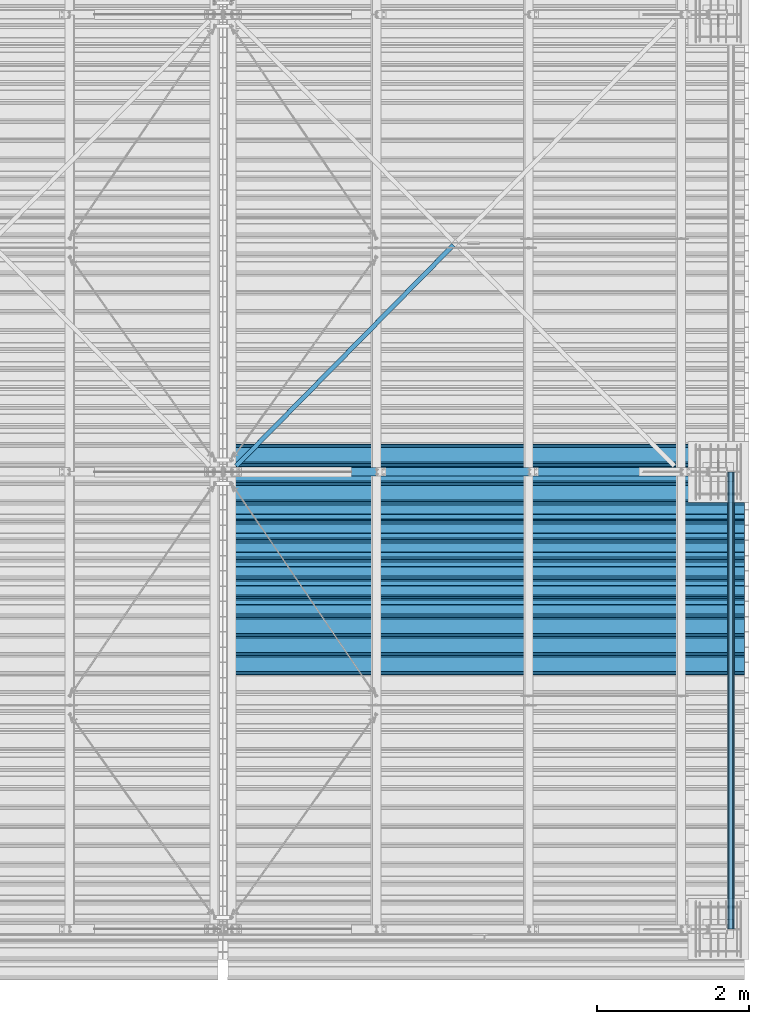
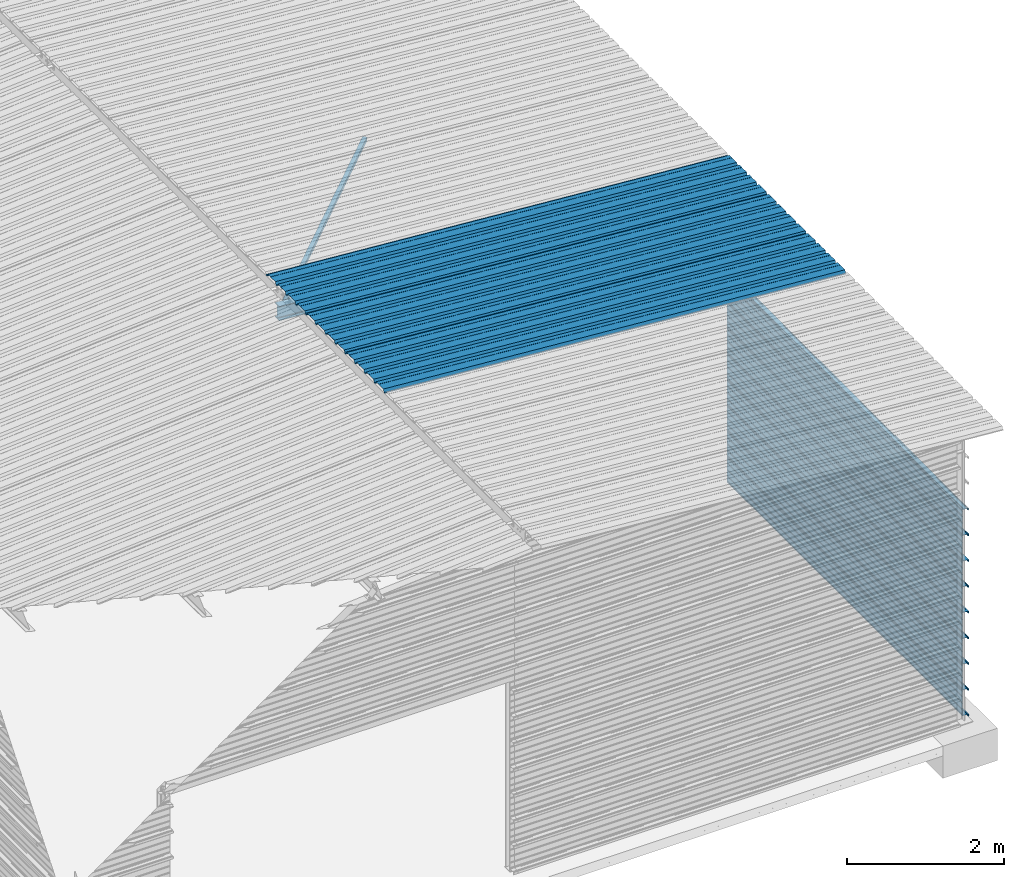
# One storey, part 9 of 70: 13 beams, 13 elements without a shape of their own.
"""IFC2X3 building model written with IfcOpenShell, lengths in millimetres."""

from ifc_helpers import new_model, si_unit, frame, origin_with_axes, origin_2d_with_axis, place, context, subcontext, project, spatial, polyline, i_section, l_section, outline, extrude, clip, halfspace, material, type_object, element, aggregate, save


model = new_model("IFC2X3")

# Units and contexts
model_context = context("Model", 3, precision=1e-05, world=origin_with_axes())
body_context = subcontext(model_context, "Body", "Model", "MODEL_VIEW")
ifc_project = project(units=[si_unit("LENGTHUNIT", "METRE", prefix="MILLI"), si_unit("AREAUNIT", "SQUARE_METRE"), si_unit("VOLUMEUNIT", "CUBIC_METRE"), si_unit("MASSUNIT", "GRAM", prefix="KILO"), si_unit("TIMEUNIT", "SECOND"), si_unit("PLANEANGLEUNIT", "RADIAN"), si_unit("SOLIDANGLEUNIT", "STERADIAN"), si_unit("THERMODYNAMICTEMPERATUREUNIT", "DEGREE_CELSIUS"), si_unit("LUMINOUSINTENSITYUNIT", "LUMEN")], contexts=[model_context])

# Site, building, storey
site_placement = place(None, origin_with_axes())
site = spatial("IfcSite", under=ifc_project, at=site_placement, CompositionType="ELEMENT")
building_placement = place(site_placement, origin_with_axes())
building = spatial("IfcBuilding", under=site, at=building_placement, Name="Undefined", CompositionType="ELEMENT")
storey_placement = place(building_placement, origin_with_axes())
storey = spatial("IfcBuildingStorey", under=building, at=storey_placement, Name="Undefined", CompositionType="ELEMENT", Elevation=0.0)

# Assembly, beam
assembly_1_placement = place(storey_placement, origin_with_axes())
assembly_1 = element("IfcElementAssembly", 1, at=assembly_1_placement, inside=storey, Name="Steel Assembly", AssemblyPlace="NOTDEFINED", PredefinedType="RIGID_FRAME")
ifc_material = material(Name="STEEL/S235JR")
beam_type_1 = type_object("IfcBeamType", Name="4.40", PredefinedType="NOTDEFINED")
beam_1_placement = place(assembly_1_placement, frame((6563.60751131961, 3850.00000000015, 5336.31760454361), z_axis=(-0.0766964990376782, 0.0, -0.997054485489817), x_axis=(0.997054485489817, 0.0, -0.0766964990376783)))
beam_1 = element("IfcBeam", 2, at=beam_1_placement, type_object=beam_type_1, material=ifc_material, ObjectType="4.40", context=body_context, shape_type="SweptSolid", body=[
    extrude(outline(polyline([(509.415161132813, 19.5000000011705), (490.584838867188, 19.5000000011705), (468.084838867188, -20.4999999988113), (406.585784912109, -20.4999999988113), (404.585784912109, -18.4999999988122), (345.414215087891, -18.4999999988122), (343.414215087891, -20.4999999988113), (281.915161132813, -20.4999999988113), (259.415161132813, 19.5000000011705), (240.584854125977, 19.5000000011705), (218.084854125977, -20.4999999988113), (156.585784912109, -20.4999999988113), (154.585784912109, -18.4999999988122), (95.4142150878906, -18.4999999988122), (93.4142150878906, -20.4999999988113), (31.9151515960693, -20.4999999988113), (9.41515254974365, 19.5000000011705), (-9.41515254974365, 19.5000000011705), (-31.9151515960693, -20.4999999988113), (-93.4142150878906, -20.4999999988113), (-95.4142150878906, -18.4999999988122), (-154.585784912109, -18.4999999988122), (-156.585784912109, -20.4999999988113), (-218.084854125977, -20.4999999988113), (-240.584854125977, 19.5000000011705), (-259.415161132813, 19.5000000011705), (-281.915161132813, -20.4999999988113), (-343.414215087891, -20.4999999988113), (-345.414215087891, -18.4999999988122), (-404.585784912109, -18.4999999988122), (-406.585784912109, -20.4999999988113), (-468.084838867188, -20.4999999988113), (-490.584838867188, 19.5000000011705), (-509.415161132813, 19.5000000011705), (-516.482360839844, 6.9361057293263), (-517.353942871094, 7.42636680720625), (-510.0, 20.5000000011705), (-490.0, 20.5000000011705), (-467.5, -19.4999999988122), (-407.0, -19.4999999988122), (-405.0, -17.4999999988131), (-345.0, -17.4999999988131), (-343.0, -19.4999999988122), (-282.5, -19.4999999988122), (-260.0, 20.5000000011705), (-240.0, 20.5000000011705), (-217.5, -19.4999999988122), (-157.0, -19.4999999988122), (-155.0, -17.4999999988131), (-95.0, -17.4999999988131), (-93.0, -19.4999999988122), (-32.5, -19.4999999988122), (-10.0, 20.5000000011705), (10.0, 20.5000000011705), (32.5, -19.4999999988122), (93.0, -19.4999999988122), (95.0, -17.4999999988131), (155.0, -17.4999999988131), (157.0, -19.4999999988122), (217.5, -19.4999999988122), (240.0, 20.5000000011705), (260.0, 20.5000000011705), (282.5, -19.4999999988122), (343.0, -19.4999999988122), (345.0, -17.4999999988131), (405.0, -17.4999999988131), (407.0, -19.4999999988122), (467.5, -19.4999999988122), (490.0, 20.5000000011705), (510.0, 20.5000000011705), (517.353942871094, 7.42636680720625), (516.482360839844, 6.9361057293263), (509.415161132813, 19.5000000011705)])), frame((6799.99999999733, 2.8421709430404e-14, 0.0), z_axis=(-1.0, 0.0, 0.0), x_axis=(0.0, -1.0, 0.0)), (0.0, 0.0, 1.0), 6800.0),
])
aggregate(assembly_1, [beam_1])

assembly_2_placement = place(storey_placement, origin_with_axes())
assembly_2 = element("IfcElementAssembly", 3, at=assembly_2_placement, inside=storey, Name="Steel Assembly", AssemblyPlace="NOTDEFINED", PredefinedType="RIGID_FRAME")
beam_2_placement = place(assembly_2_placement, frame((6563.60751131961, 4850.00000000015, 5336.31760454364), z_axis=(-0.0766964990376782, 0.0, -0.997054485489817), x_axis=(0.997054485489817, 0.0, -0.0766964990376783)))
beam_2 = element("IfcBeam", 4, at=beam_2_placement, type_object=beam_type_1, material=ifc_material, ObjectType="4.40", context=body_context, shape_type="SweptSolid", body=[
    extrude(outline(polyline([(509.415161132813, 19.5000000011705), (490.584838867188, 19.5000000011705), (468.084838867188, -20.4999999988113), (406.585784912109, -20.4999999988113), (404.585784912109, -18.4999999988122), (345.414215087891, -18.4999999988122), (343.414215087891, -20.4999999988113), (281.915161132813, -20.4999999988113), (259.415161132813, 19.5000000011705), (240.584854125977, 19.5000000011705), (218.084854125977, -20.4999999988113), (156.585784912109, -20.4999999988113), (154.585784912109, -18.4999999988122), (95.4142150878906, -18.4999999988122), (93.4142150878906, -20.4999999988113), (31.9151515960693, -20.4999999988113), (9.41515254974365, 19.5000000011705), (-9.41515254974365, 19.5000000011705), (-31.9151515960693, -20.4999999988113), (-93.4142150878906, -20.4999999988113), (-95.4142150878906, -18.4999999988122), (-154.585784912109, -18.4999999988122), (-156.585784912109, -20.4999999988113), (-218.084854125977, -20.4999999988113), (-240.584854125977, 19.5000000011705), (-259.415161132813, 19.5000000011705), (-281.915161132813, -20.4999999988113), (-343.414215087891, -20.4999999988113), (-345.414215087891, -18.4999999988122), (-404.585784912109, -18.4999999988122), (-406.585784912109, -20.4999999988113), (-468.084838867188, -20.4999999988113), (-490.584838867188, 19.5000000011705), (-509.415161132813, 19.5000000011705), (-516.482360839844, 6.9361057293263), (-517.353942871094, 7.42636680720625), (-510.0, 20.5000000011705), (-490.0, 20.5000000011705), (-467.5, -19.4999999988122), (-407.0, -19.4999999988122), (-405.0, -17.4999999988131), (-345.0, -17.4999999988131), (-343.0, -19.4999999988122), (-282.5, -19.4999999988122), (-260.0, 20.5000000011705), (-240.0, 20.5000000011705), (-217.5, -19.4999999988122), (-157.0, -19.4999999988122), (-155.0, -17.4999999988131), (-95.0, -17.4999999988131), (-93.0, -19.4999999988122), (-32.5, -19.4999999988122), (-10.0, 20.5000000011705), (10.0, 20.5000000011705), (32.5, -19.4999999988122), (93.0, -19.4999999988122), (95.0, -17.4999999988131), (155.0, -17.4999999988131), (157.0, -19.4999999988122), (217.5, -19.4999999988122), (240.0, 20.5000000011705), (260.0, 20.5000000011705), (282.5, -19.4999999988122), (343.0, -19.4999999988122), (345.0, -17.4999999988131), (405.0, -17.4999999988131), (407.0, -19.4999999988122), (467.5, -19.4999999988122), (490.0, 20.5000000011705), (510.0, 20.5000000011705), (517.353942871094, 7.42636680720625), (516.482360839844, 6.9361057293263), (509.415161132813, 19.5000000011705)])), frame((6799.99999999733, 2.8421709430404e-14, 0.0), z_axis=(-1.0, 0.0, 0.0), x_axis=(0.0, -1.0, 0.0)), (0.0, 0.0, 1.0), 6800.0),
])
aggregate(assembly_2, [beam_2])

assembly_3_placement = place(storey_placement, origin_with_axes())
assembly_3 = element("IfcElementAssembly", 5, at=assembly_3_placement, inside=storey, Name="Steel Assembly", AssemblyPlace="NOTDEFINED", PredefinedType="RIGID_FRAME")
beam_3_placement = place(assembly_3_placement, frame((6563.60751131961, 5850.00000000015, 5336.31760454367), z_axis=(-0.0766964990376782, 0.0, -0.997054485489817), x_axis=(0.997054485489817, 0.0, -0.0766964990376783)))
beam_3 = element("IfcBeam", 6, at=beam_3_placement, type_object=beam_type_1, material=ifc_material, ObjectType="4.40", context=body_context, shape_type="SweptSolid", body=[
    extrude(outline(polyline([(509.415161132813, 19.5000000011705), (490.584838867188, 19.5000000011705), (468.084838867188, -20.4999999988113), (406.585784912109, -20.4999999988113), (404.585784912109, -18.4999999988122), (345.414215087891, -18.4999999988122), (343.414215087891, -20.4999999988113), (281.915161132813, -20.4999999988113), (259.415161132813, 19.5000000011705), (240.584854125977, 19.5000000011705), (218.084854125977, -20.4999999988113), (156.585784912109, -20.4999999988113), (154.585784912109, -18.4999999988122), (95.4142150878906, -18.4999999988122), (93.4142150878906, -20.4999999988113), (31.9151515960693, -20.4999999988113), (9.41515254974365, 19.5000000011705), (-9.41515254974365, 19.5000000011705), (-31.9151515960693, -20.4999999988113), (-93.4142150878906, -20.4999999988113), (-95.4142150878906, -18.4999999988122), (-154.585784912109, -18.4999999988122), (-156.585784912109, -20.4999999988113), (-218.084854125977, -20.4999999988113), (-240.584854125977, 19.5000000011705), (-259.415161132813, 19.5000000011705), (-281.915161132813, -20.4999999988113), (-343.414215087891, -20.4999999988113), (-345.414215087891, -18.4999999988122), (-404.585784912109, -18.4999999988122), (-406.585784912109, -20.4999999988113), (-468.084838867188, -20.4999999988113), (-490.584838867188, 19.5000000011705), (-509.415161132813, 19.5000000011705), (-516.482360839844, 6.9361057293263), (-517.353942871094, 7.42636680720625), (-510.0, 20.5000000011705), (-490.0, 20.5000000011705), (-467.5, -19.4999999988122), (-407.0, -19.4999999988122), (-405.0, -17.4999999988131), (-345.0, -17.4999999988131), (-343.0, -19.4999999988122), (-282.5, -19.4999999988122), (-260.0, 20.5000000011705), (-240.0, 20.5000000011705), (-217.5, -19.4999999988122), (-157.0, -19.4999999988122), (-155.0, -17.4999999988131), (-95.0, -17.4999999988131), (-93.0, -19.4999999988122), (-32.5, -19.4999999988122), (-10.0, 20.5000000011705), (10.0, 20.5000000011705), (32.5, -19.4999999988122), (93.0, -19.4999999988122), (95.0, -17.4999999988131), (155.0, -17.4999999988131), (157.0, -19.4999999988122), (217.5, -19.4999999988122), (240.0, 20.5000000011705), (260.0, 20.5000000011705), (282.5, -19.4999999988122), (343.0, -19.4999999988122), (345.0, -17.4999999988131), (405.0, -17.4999999988131), (407.0, -19.4999999988122), (467.5, -19.4999999988122), (490.0, 20.5000000011705), (510.0, 20.5000000011705), (517.353942871094, 7.42636680720625), (516.482360839844, 6.9361057293263), (509.415161132813, 19.5000000011705)])), frame((6799.99999999733, 2.8421709430404e-14, 0.0), z_axis=(-1.0, 0.0, 0.0), x_axis=(0.0, -1.0, 0.0)), (0.0, 0.0, 1.0), 6800.0),
])
aggregate(assembly_3, [beam_3])

assembly_4_placement = place(storey_placement, origin_with_axes())
assembly_4 = element("IfcElementAssembly", 7, at=assembly_4_placement, inside=storey, Name="Steel Assembly", AssemblyPlace="NOTDEFINED", PredefinedType="RIGID_FRAME")
beam_type_2 = type_object("IfcBeamType", Name="400", PredefinedType="NOTDEFINED")
beam_4_placement = place(assembly_4_placement, frame((13165.4999999989, 6000.0, 3018.17396601053), z_axis=(1.0, 0.0, 0.0), x_axis=(0.0, -1.0, 0.0)))
beam_4 = element("IfcBeam", 8, at=beam_4_placement, type_object=beam_type_2, material=ifc_material, ObjectType="400", context=body_context, shape_type="SweptSolid", body=[
    extrude(outline(polyline([(218.25, -24.994083404541), (214.25, -31.8999996185303), (214.25, -45.5), (199.75, -45.5), (194.25, -42.5), (188.75, -45.5), (124.25, -45.5), (114.25, -41.5), (104.25, -45.5), (24.25, -45.5), (14.25, -41.5), (4.25, -45.5), (-75.75, -45.5), (-85.75, -41.5), (-95.75, -45.5), (-160.25, -45.5), (-165.75, -42.5), (-171.25, -45.5), (-185.75, -45.5), (-185.75, -30.711540222168), (-181.75, -23.8111782073975), (-181.75, 23.311637878418), (-185.75, 30.2119998931885), (-185.75, 44.5), (-217.25, 44.5), (-217.25, 34.7999992370605), (-218.25, 34.7999992370605), (-218.25, 45.5), (-184.75, 45.5), (-184.75, 30.480884552002), (-180.75, 23.5805225372314), (-180.75, -24.0800628662109), (-184.75, -30.9804248809814), (-184.75, -44.5), (-171.504989624023, -44.5), (-165.75, -41.360912322998), (-159.995010375977, -44.5), (-95.9425811767578, -44.5), (-85.75, -40.422966003418), (-75.5574188232422, -44.5), (4.05741739273071, -44.5), (14.25, -40.422966003418), (24.4425830841064, -44.5), (104.057418823242, -44.5), (114.25, -40.422966003418), (124.442581176758, -44.5), (188.495010375977, -44.5), (194.25, -41.360912322998), (200.004989624023, -44.5), (213.25, -44.5), (213.25, -31.6313018798828), (217.25, -24.7253856658936), (217.25, 21.7253856658936), (213.25, 28.6313018798828), (213.25, 42.0), (187.25, 42.0), (187.25, 32.5499992370605), (186.25, 32.5499992370605), (186.25, 43.0), (214.25, 43.0), (214.25, 28.8999996185303), (218.25, 21.994083404541), (218.25, -24.994083404541)])), frame((6000.0, 0.0, 0.0), z_axis=(-1.0, 0.0, 0.0), x_axis=(0.0, -1.0, 0.0)), (0.0, 0.0, 1.0), 6000.0),
])
aggregate(assembly_4, [beam_4])

assembly_5_placement = place(storey_placement, origin_with_axes())
assembly_5 = element("IfcElementAssembly", 9, at=assembly_5_placement, inside=storey, Name="Steel Assembly", AssemblyPlace="NOTDEFINED", PredefinedType="RIGID_FRAME")
beam_5_placement = place(assembly_5_placement, frame((13165.4999999991, 6000.0, 2618.17396601053), z_axis=(1.0, 0.0, 0.0), x_axis=(0.0, -1.0, 0.0)))
beam_5 = element("IfcBeam", 10, at=beam_5_placement, type_object=beam_type_2, material=ifc_material, ObjectType="400", context=body_context, shape_type="SweptSolid", body=[
    extrude(outline(polyline([(218.25, -24.994083404541), (214.25, -31.8999996185303), (214.25, -45.5), (199.75, -45.5), (194.25, -42.5), (188.75, -45.5), (124.25, -45.5), (114.25, -41.5), (104.25, -45.5), (24.25, -45.5), (14.25, -41.5), (4.25, -45.5), (-75.75, -45.5), (-85.75, -41.5), (-95.75, -45.5), (-160.25, -45.5), (-165.75, -42.5), (-171.25, -45.5), (-185.75, -45.5), (-185.75, -30.711540222168), (-181.75, -23.8111782073975), (-181.75, 23.311637878418), (-185.75, 30.2119998931885), (-185.75, 44.5), (-217.25, 44.5), (-217.25, 34.7999992370605), (-218.25, 34.7999992370605), (-218.25, 45.5), (-184.75, 45.5), (-184.75, 30.480884552002), (-180.75, 23.5805225372314), (-180.75, -24.0800628662109), (-184.75, -30.9804248809814), (-184.75, -44.5), (-171.504989624023, -44.5), (-165.75, -41.360912322998), (-159.995010375977, -44.5), (-95.9425811767578, -44.5), (-85.75, -40.422966003418), (-75.5574188232422, -44.5), (4.05741739273071, -44.5), (14.25, -40.422966003418), (24.4425830841064, -44.5), (104.057418823242, -44.5), (114.25, -40.422966003418), (124.442581176758, -44.5), (188.495010375977, -44.5), (194.25, -41.360912322998), (200.004989624023, -44.5), (213.25, -44.5), (213.25, -31.6313018798828), (217.25, -24.7253856658936), (217.25, 21.7253856658936), (213.25, 28.6313018798828), (213.25, 42.0), (187.25, 42.0), (187.25, 32.5499992370605), (186.25, 32.5499992370605), (186.25, 43.0), (214.25, 43.0), (214.25, 28.8999996185303), (218.25, 21.994083404541), (218.25, -24.994083404541)])), frame((6000.0, 0.0, 0.0), z_axis=(-1.0, 0.0, 0.0), x_axis=(0.0, -1.0, 0.0)), (0.0, 0.0, 1.0), 6000.0),
])
aggregate(assembly_5, [beam_5])

assembly_6_placement = place(storey_placement, origin_with_axes())
assembly_6 = element("IfcElementAssembly", 11, at=assembly_6_placement, inside=storey, Name="Steel Assembly", AssemblyPlace="NOTDEFINED", PredefinedType="RIGID_FRAME")
beam_6_placement = place(assembly_6_placement, frame((13165.4999999992, 6000.0, 2218.17396601053), z_axis=(1.0, 0.0, 0.0), x_axis=(0.0, -1.0, 0.0)))
beam_6 = element("IfcBeam", 12, at=beam_6_placement, type_object=beam_type_2, material=ifc_material, ObjectType="400", context=body_context, shape_type="SweptSolid", body=[
    extrude(outline(polyline([(218.25, -24.994083404541), (214.25, -31.8999996185303), (214.25, -45.5), (199.75, -45.5), (194.25, -42.5), (188.75, -45.5), (124.25, -45.5), (114.25, -41.5), (104.25, -45.5), (24.25, -45.5), (14.25, -41.5), (4.25, -45.5), (-75.75, -45.5), (-85.75, -41.5), (-95.75, -45.5), (-160.25, -45.5), (-165.75, -42.5), (-171.25, -45.5), (-185.75, -45.5), (-185.75, -30.711540222168), (-181.75, -23.8111782073975), (-181.75, 23.311637878418), (-185.75, 30.2119998931885), (-185.75, 44.5), (-217.25, 44.5), (-217.25, 34.7999992370605), (-218.25, 34.7999992370605), (-218.25, 45.5), (-184.75, 45.5), (-184.75, 30.480884552002), (-180.75, 23.5805225372314), (-180.75, -24.0800628662109), (-184.75, -30.9804248809814), (-184.75, -44.5), (-171.504989624023, -44.5), (-165.75, -41.360912322998), (-159.995010375977, -44.5), (-95.9425811767578, -44.5), (-85.75, -40.422966003418), (-75.5574188232422, -44.5), (4.05741739273071, -44.5), (14.25, -40.422966003418), (24.4425830841064, -44.5), (104.057418823242, -44.5), (114.25, -40.422966003418), (124.442581176758, -44.5), (188.495010375977, -44.5), (194.25, -41.360912322998), (200.004989624023, -44.5), (213.25, -44.5), (213.25, -31.6313018798828), (217.25, -24.7253856658936), (217.25, 21.7253856658936), (213.25, 28.6313018798828), (213.25, 42.0), (187.25, 42.0), (187.25, 32.5499992370605), (186.25, 32.5499992370605), (186.25, 43.0), (214.25, 43.0), (214.25, 28.8999996185303), (218.25, 21.994083404541), (218.25, -24.994083404541)])), frame((6000.0, 0.0, 0.0), z_axis=(-1.0, 0.0, 0.0), x_axis=(0.0, -1.0, 0.0)), (0.0, 0.0, 1.0), 6000.0),
])
aggregate(assembly_6, [beam_6])

assembly_7_placement = place(storey_placement, origin_with_axes())
assembly_7 = element("IfcElementAssembly", 13, at=assembly_7_placement, inside=storey, Name="Steel Assembly", AssemblyPlace="NOTDEFINED", PredefinedType="RIGID_FRAME")
beam_7_placement = place(assembly_7_placement, frame((13165.4999999994, 6000.0, 1818.17396601053), z_axis=(1.0, 0.0, 0.0), x_axis=(0.0, -1.0, 0.0)))
beam_7 = element("IfcBeam", 14, at=beam_7_placement, type_object=beam_type_2, material=ifc_material, ObjectType="400", context=body_context, shape_type="SweptSolid", body=[
    extrude(outline(polyline([(218.25, -24.994083404541), (214.25, -31.8999996185303), (214.25, -45.5), (199.75, -45.5), (194.25, -42.5), (188.75, -45.5), (124.25, -45.5), (114.25, -41.5), (104.25, -45.5), (24.25, -45.5), (14.25, -41.5), (4.25, -45.5), (-75.75, -45.5), (-85.75, -41.5), (-95.75, -45.5), (-160.25, -45.5), (-165.75, -42.5), (-171.25, -45.5), (-185.75, -45.5), (-185.75, -30.711540222168), (-181.75, -23.8111782073975), (-181.75, 23.311637878418), (-185.75, 30.2119998931885), (-185.75, 44.5), (-217.25, 44.5), (-217.25, 34.7999992370605), (-218.25, 34.7999992370605), (-218.25, 45.5), (-184.75, 45.5), (-184.75, 30.480884552002), (-180.75, 23.5805225372314), (-180.75, -24.0800628662109), (-184.75, -30.9804248809814), (-184.75, -44.5), (-171.504989624023, -44.5), (-165.75, -41.360912322998), (-159.995010375977, -44.5), (-95.9425811767578, -44.5), (-85.75, -40.422966003418), (-75.5574188232422, -44.5), (4.05741739273071, -44.5), (14.25, -40.422966003418), (24.4425830841064, -44.5), (104.057418823242, -44.5), (114.25, -40.422966003418), (124.442581176758, -44.5), (188.495010375977, -44.5), (194.25, -41.360912322998), (200.004989624023, -44.5), (213.25, -44.5), (213.25, -31.6313018798828), (217.25, -24.7253856658936), (217.25, 21.7253856658936), (213.25, 28.6313018798828), (213.25, 42.0), (187.25, 42.0), (187.25, 32.5499992370605), (186.25, 32.5499992370605), (186.25, 43.0), (214.25, 43.0), (214.25, 28.8999996185303), (218.25, 21.994083404541), (218.25, -24.994083404541)])), frame((6000.0, 0.0, 0.0), z_axis=(-1.0, 0.0, 0.0), x_axis=(0.0, -1.0, 0.0)), (0.0, 0.0, 1.0), 6000.0),
])
aggregate(assembly_7, [beam_7])

assembly_8_placement = place(storey_placement, origin_with_axes())
assembly_8 = element("IfcElementAssembly", 15, at=assembly_8_placement, inside=storey, Name="Steel Assembly", AssemblyPlace="NOTDEFINED", PredefinedType="RIGID_FRAME")
beam_8_placement = place(assembly_8_placement, frame((13165.4999999995, 6000.0, 1418.17396601053), z_axis=(1.0, 0.0, 0.0), x_axis=(0.0, -1.0, 0.0)))
beam_8 = element("IfcBeam", 16, at=beam_8_placement, type_object=beam_type_2, material=ifc_material, ObjectType="400", context=body_context, shape_type="SweptSolid", body=[
    extrude(outline(polyline([(218.25, -24.994083404541), (214.25, -31.8999996185303), (214.25, -45.5), (199.75, -45.5), (194.25, -42.5), (188.75, -45.5), (124.25, -45.5), (114.25, -41.5), (104.25, -45.5), (24.25, -45.5), (14.25, -41.5), (4.25, -45.5), (-75.75, -45.5), (-85.75, -41.5), (-95.75, -45.5), (-160.25, -45.5), (-165.75, -42.5), (-171.25, -45.5), (-185.75, -45.5), (-185.75, -30.711540222168), (-181.75, -23.8111782073975), (-181.75, 23.311637878418), (-185.75, 30.2119998931885), (-185.75, 44.5), (-217.25, 44.5), (-217.25, 34.7999992370605), (-218.25, 34.7999992370605), (-218.25, 45.5), (-184.75, 45.5), (-184.75, 30.480884552002), (-180.75, 23.5805225372314), (-180.75, -24.0800628662109), (-184.75, -30.9804248809814), (-184.75, -44.5), (-171.504989624023, -44.5), (-165.75, -41.360912322998), (-159.995010375977, -44.5), (-95.9425811767578, -44.5), (-85.75, -40.422966003418), (-75.5574188232422, -44.5), (4.05741739273071, -44.5), (14.25, -40.422966003418), (24.4425830841064, -44.5), (104.057418823242, -44.5), (114.25, -40.422966003418), (124.442581176758, -44.5), (188.495010375977, -44.5), (194.25, -41.360912322998), (200.004989624023, -44.5), (213.25, -44.5), (213.25, -31.6313018798828), (217.25, -24.7253856658936), (217.25, 21.7253856658936), (213.25, 28.6313018798828), (213.25, 42.0), (187.25, 42.0), (187.25, 32.5499992370605), (186.25, 32.5499992370605), (186.25, 43.0), (214.25, 43.0), (214.25, 28.8999996185303), (218.25, 21.994083404541), (218.25, -24.994083404541)])), frame((6000.0, 0.0, 0.0), z_axis=(-1.0, 0.0, 0.0), x_axis=(0.0, -1.0, 0.0)), (0.0, 0.0, 1.0), 6000.0),
])
aggregate(assembly_8, [beam_8])

assembly_9_placement = place(storey_placement, origin_with_axes())
assembly_9 = element("IfcElementAssembly", 17, at=assembly_9_placement, inside=storey, Name="Steel Assembly", AssemblyPlace="NOTDEFINED", PredefinedType="RIGID_FRAME")
beam_9_placement = place(assembly_9_placement, frame((13165.4999999997, 6000.0, 1018.17396601053), z_axis=(1.0, 0.0, 0.0), x_axis=(0.0, -1.0, 0.0)))
beam_9 = element("IfcBeam", 18, at=beam_9_placement, type_object=beam_type_2, material=ifc_material, ObjectType="400", context=body_context, shape_type="SweptSolid", body=[
    extrude(outline(polyline([(218.25, -24.994083404541), (214.25, -31.8999996185303), (214.25, -45.5), (199.75, -45.5), (194.25, -42.5), (188.75, -45.5), (124.25, -45.5), (114.25, -41.5), (104.25, -45.5), (24.25, -45.5), (14.25, -41.5), (4.25, -45.5), (-75.75, -45.5), (-85.75, -41.5), (-95.75, -45.5), (-160.25, -45.5), (-165.75, -42.5), (-171.25, -45.5), (-185.75, -45.5), (-185.75, -30.711540222168), (-181.75, -23.8111782073975), (-181.75, 23.311637878418), (-185.75, 30.2119998931885), (-185.75, 44.5), (-217.25, 44.5), (-217.25, 34.7999992370605), (-218.25, 34.7999992370605), (-218.25, 45.5), (-184.75, 45.5), (-184.75, 30.480884552002), (-180.75, 23.5805225372314), (-180.75, -24.0800628662109), (-184.75, -30.9804248809814), (-184.75, -44.5), (-171.504989624023, -44.5), (-165.75, -41.360912322998), (-159.995010375977, -44.5), (-95.9425811767578, -44.5), (-85.75, -40.422966003418), (-75.5574188232422, -44.5), (4.05741739273071, -44.5), (14.25, -40.422966003418), (24.4425830841064, -44.5), (104.057418823242, -44.5), (114.25, -40.422966003418), (124.442581176758, -44.5), (188.495010375977, -44.5), (194.25, -41.360912322998), (200.004989624023, -44.5), (213.25, -44.5), (213.25, -31.6313018798828), (217.25, -24.7253856658936), (217.25, 21.7253856658936), (213.25, 28.6313018798828), (213.25, 42.0), (187.25, 42.0), (187.25, 32.5499992370605), (186.25, 32.5499992370605), (186.25, 43.0), (214.25, 43.0), (214.25, 28.8999996185303), (218.25, 21.994083404541), (218.25, -24.994083404541)])), frame((6000.0, 0.0, 0.0), z_axis=(-1.0, 0.0, 0.0), x_axis=(0.0, -1.0, 0.0)), (0.0, 0.0, 1.0), 6000.0),
])
aggregate(assembly_9, [beam_9])

assembly_10_placement = place(storey_placement, origin_with_axes())
assembly_10 = element("IfcElementAssembly", 19, at=assembly_10_placement, inside=storey, Name="Steel Assembly", AssemblyPlace="NOTDEFINED", PredefinedType="RIGID_FRAME")
beam_10_placement = place(assembly_10_placement, frame((13165.4999999998, 6000.0, 618.173966010529), z_axis=(1.0, 0.0, 0.0), x_axis=(0.0, -1.0, 0.0)))
beam_10 = element("IfcBeam", 20, at=beam_10_placement, type_object=beam_type_2, material=ifc_material, ObjectType="400", context=body_context, shape_type="SweptSolid", body=[
    extrude(outline(polyline([(218.25, -24.994083404541), (214.25, -31.8999996185303), (214.25, -45.5), (199.75, -45.5), (194.25, -42.5), (188.75, -45.5), (124.25, -45.5), (114.25, -41.5), (104.25, -45.5), (24.25, -45.5), (14.25, -41.5), (4.25, -45.5), (-75.75, -45.5), (-85.75, -41.5), (-95.75, -45.5), (-160.25, -45.5), (-165.75, -42.5), (-171.25, -45.5), (-185.75, -45.5), (-185.75, -30.711540222168), (-181.75, -23.8111782073975), (-181.75, 23.311637878418), (-185.75, 30.2119998931885), (-185.75, 44.5), (-217.25, 44.5), (-217.25, 34.7999992370605), (-218.25, 34.7999992370605), (-218.25, 45.5), (-184.75, 45.5), (-184.75, 30.480884552002), (-180.75, 23.5805225372314), (-180.75, -24.0800628662109), (-184.75, -30.9804248809814), (-184.75, -44.5), (-171.504989624023, -44.5), (-165.75, -41.360912322998), (-159.995010375977, -44.5), (-95.9425811767578, -44.5), (-85.75, -40.422966003418), (-75.5574188232422, -44.5), (4.05741739273071, -44.5), (14.25, -40.422966003418), (24.4425830841064, -44.5), (104.057418823242, -44.5), (114.25, -40.422966003418), (124.442581176758, -44.5), (188.495010375977, -44.5), (194.25, -41.360912322998), (200.004989624023, -44.5), (213.25, -44.5), (213.25, -31.6313018798828), (217.25, -24.7253856658936), (217.25, 21.7253856658936), (213.25, 28.6313018798828), (213.25, 42.0), (187.25, 42.0), (187.25, 32.5499992370605), (186.25, 32.5499992370605), (186.25, 43.0), (214.25, 43.0), (214.25, 28.8999996185303), (218.25, 21.994083404541), (218.25, -24.994083404541)])), frame((6000.0, 0.0, 0.0), z_axis=(-1.0, 0.0, 0.0), x_axis=(0.0, -1.0, 0.0)), (0.0, 0.0, 1.0), 6000.0),
])
aggregate(assembly_10, [beam_10])

assembly_11_placement = place(storey_placement, origin_with_axes())
assembly_11 = element("IfcElementAssembly", 21, at=assembly_11_placement, inside=storey, Name="Steel Assembly", AssemblyPlace="NOTDEFINED", PredefinedType="RIGID_FRAME")
beam_11_placement = place(assembly_11_placement, frame((13165.5, 6000.0, 218.173966010529), z_axis=(1.0, 0.0, 0.0), x_axis=(0.0, -1.0, 0.0)))
beam_11 = element("IfcBeam", 22, at=beam_11_placement, type_object=beam_type_2, material=ifc_material, ObjectType="400", context=body_context, shape_type="SweptSolid", body=[
    extrude(outline(polyline([(218.25, -24.994083404541), (214.25, -31.8999996185303), (214.25, -45.5), (199.75, -45.5), (194.25, -42.5), (188.75, -45.5), (124.25, -45.5), (114.25, -41.5), (104.25, -45.5), (24.25, -45.5), (14.25, -41.5), (4.25, -45.5), (-75.75, -45.5), (-85.75, -41.5), (-95.75, -45.5), (-160.25, -45.5), (-165.75, -42.5), (-171.25, -45.5), (-185.75, -45.5), (-185.75, -30.711540222168), (-181.75, -23.8111782073975), (-181.75, 23.311637878418), (-185.75, 30.2119998931885), (-185.75, 44.5), (-217.25, 44.5), (-217.25, 34.7999992370605), (-218.25, 34.7999992370605), (-218.25, 45.5), (-184.75, 45.5), (-184.75, 30.480884552002), (-180.75, 23.5805225372314), (-180.75, -24.0800628662109), (-184.75, -30.9804248809814), (-184.75, -44.5), (-171.504989624023, -44.5), (-165.75, -41.360912322998), (-159.995010375977, -44.5), (-95.9425811767578, -44.5), (-85.75, -40.422966003418), (-75.5574188232422, -44.5), (4.05741739273071, -44.5), (14.25, -40.422966003418), (24.4425830841064, -44.5), (104.057418823242, -44.5), (114.25, -40.422966003418), (124.442581176758, -44.5), (188.495010375977, -44.5), (194.25, -41.360912322998), (200.004989624023, -44.5), (213.25, -44.5), (213.25, -31.6313018798828), (217.25, -24.7253856658936), (217.25, 21.7253856658936), (213.25, 28.6313018798828), (213.25, 42.0), (187.25, 42.0), (187.25, 32.5499992370605), (186.25, 32.5499992370605), (186.25, 43.0), (214.25, 43.0), (214.25, 28.8999996185303), (218.25, 21.994083404541), (218.25, -24.994083404541)])), frame((6000.0, 0.0, 0.0), z_axis=(-1.0, 0.0, 0.0), x_axis=(0.0, -1.0, 0.0)), (0.0, 0.0, 1.0), 6000.0),
])
aggregate(assembly_11, [beam_11])

assembly_12_placement = place(storey_placement, origin_with_axes())
assembly_12 = element("IfcElementAssembly", 23, at=assembly_12_placement, inside=storey, Name="Steel Assembly", AssemblyPlace="NOTDEFINED", PredefinedType="RIGID_FRAME")
beam_type_3 = type_object("IfcBeamType", PredefinedType="NOTDEFINED")
beam_12_placement = place(assembly_12_placement, frame((6670.75556216974, 6076.0657235175, 5039.52551794915), z_axis=(-0.0766964990376782, 0.0, -0.997054485489817), x_axis=(0.700122412215615, 0.711988894219269, -0.0538555700165857)))
beam_12 = element("IfcBeam", 24, at=beam_12_placement, type_object=beam_type_3, material=ifc_material, Name="POUTRE", context=body_context, shape_type="Clipping", body=[
    clip(extrude(l_section(Depth=60.0, Width=60.0, Thickness=6.0, FilletRadius=8.0, EdgeRadius=4.0, at=origin_2d_with_axis()), frame((4136.90804481534, 1.75894358534081e-12, 0.0), z_axis=(-1.0, 0.0, 0.0), x_axis=(0.0, -1.0, 0.0)), (0.0, 0.0, 1.0), 4136.91), halfspace(frame((4072.73442480484, 30.0000000079531, -7.95353116700426e-09), z_axis=(-1.0, 0.0, 0.0), x_axis=(0.0, 0.0, 1.0)), True)),
])
aggregate(assembly_12, [beam_12])

assembly_13_placement = place(storey_placement, origin_with_axes())
assembly_13 = element("IfcElementAssembly", 25, at=assembly_13_placement, inside=storey, Name="Steel Assembly", AssemblyPlace="NOTDEFINED", PredefinedType="RIGID_FRAME")
beam_type_4 = type_object("IfcBeamType", Name="IPE220", PredefinedType="NOTDEFINED")
beam_13_placement = place(assembly_13_placement, frame((6491.56338512267, 6000.0, 4990.32400659478), z_axis=(0.0766964990376782, 0.0, 0.997054485489817), x_axis=(0.997054485489817, 0.0, -0.0766964990376783)))
beam_13 = element("IfcBeam", 26, at=beam_13_placement, type_object=beam_type_4, material=ifc_material, Name="POUTRE", ObjectType="IPE220", context=body_context, shape_type="Clipping", body=[
    clip(clip(extrude(i_section(OverallWidth=110.0, OverallDepth=220.0, WebThickness=5.900000095, FlangeThickness=9.199999809, FilletRadius=12.0, at=origin_2d_with_axis()), frame((6409.35743228136, 3.63797880709171e-12, 8.89477024296393e-14), z_axis=(-1.0, 0.0, 0.0), x_axis=(0.0, -1.0, 0.0)), (0.0, 0.0, 1.0), 6402.94), halfspace(frame((6400.72666295692, 3.63797880709171e-12, -109.999999009079), z_axis=(-0.997054485489818, 0.0, -0.0766964990376602), x_axis=(-0.0766964990376602, 0.0, 0.997054485489818)), True)), halfspace(frame((14.9558139963001, 3.63797880709171e-12, 111.150447485664), z_axis=(-0.997054485489818, 0.0, -0.0766964990376602), x_axis=(0.0, -1.0, 0.0)), False)),
])
aggregate(assembly_13, [beam_13])

save(model, "model.ifc")
